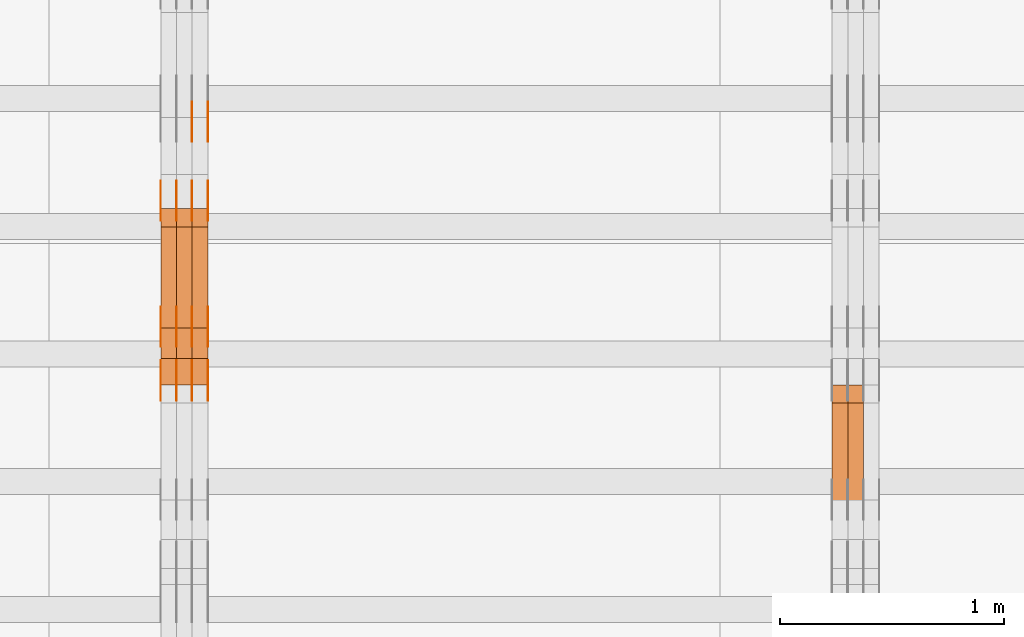
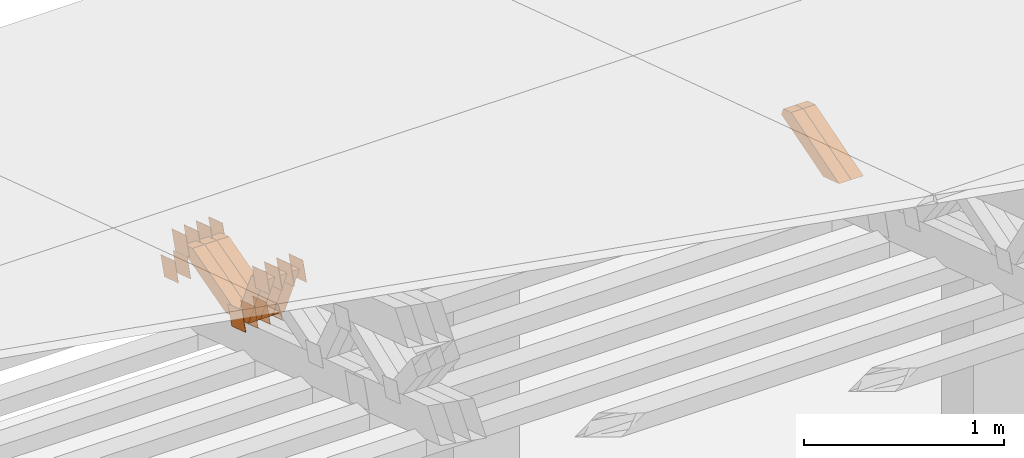
# One storey, part 217 of 385: 28 proxies.
"""IFC2X3 building model written with IfcOpenShell, lengths in millimetres."""

from ifc_helpers import new_model, entity, si_unit, converted_unit, derived_unit, direction, frame, origin, place, context, subcontext, project, spatial, polyline, outline, extrude, source, transform, mapped, material, type_object, type_shapes, element, save


model = new_model("IFC2X3")

# Units and contexts
model_context = context("Model", 3, precision=0.01, world=origin(), true_north=direction((6.12303176911189e-17, 1.0)))
body_context = subcontext(model_context, "Body", "Model", "MODEL_VIEW")
ifc_project = project(units=[si_unit("LENGTHUNIT", "METRE", prefix="MILLI"), si_unit("AREAUNIT", "SQUARE_METRE"), si_unit("VOLUMEUNIT", "CUBIC_METRE"), converted_unit("PLANEANGLEUNIT", "DEGREE", entity("IfcRatioMeasure", 0.0174532925199433), si_unit("PLANEANGLEUNIT", "RADIAN"), dimensions=[0, 0, 0, 0, 0, 0, 0]), si_unit("MASSUNIT", "GRAM", prefix="KILO"), derived_unit("MASSDENSITYUNIT", [(si_unit("MASSUNIT", "GRAM", prefix="KILO"), 1), (si_unit("LENGTHUNIT", "METRE"), -3)]), si_unit("TIMEUNIT", "SECOND"), si_unit("FREQUENCYUNIT", "HERTZ"), si_unit("THERMODYNAMICTEMPERATUREUNIT", "DEGREE_CELSIUS"), derived_unit("THERMALTRANSMITTANCEUNIT", [(si_unit("MASSUNIT", "GRAM", prefix="KILO"), 1), (si_unit("THERMODYNAMICTEMPERATUREUNIT", "KELVIN"), -1), (si_unit("TIMEUNIT", "SECOND"), -3)]), derived_unit("VOLUMETRICFLOWRATEUNIT", [(si_unit("LENGTHUNIT", "METRE"), 3), (si_unit("TIMEUNIT", "SECOND"), -1)]), si_unit("ELECTRICCURRENTUNIT", "AMPERE"), si_unit("ELECTRICVOLTAGEUNIT", "VOLT"), si_unit("POWERUNIT", "WATT"), si_unit("FORCEUNIT", "NEWTON", prefix="KILO"), si_unit("ILLUMINANCEUNIT", "LUX"), si_unit("LUMINOUSFLUXUNIT", "LUMEN"), si_unit("LUMINOUSINTENSITYUNIT", "CANDELA"), derived_unit("USERDEFINED", [(si_unit("MASSUNIT", "GRAM", prefix="KILO"), -1), (si_unit("LENGTHUNIT", "METRE"), -2), (si_unit("TIMEUNIT", "SECOND"), 3), (si_unit("LUMINOUSFLUXUNIT", "LUMEN"), 1)]), derived_unit("LINEARVELOCITYUNIT", [(si_unit("LENGTHUNIT", "METRE"), 1), (si_unit("TIMEUNIT", "SECOND"), -1)]), si_unit("PRESSUREUNIT", "PASCAL"), derived_unit("USERDEFINED", [(si_unit("LENGTHUNIT", "METRE"), -2), (si_unit("MASSUNIT", "GRAM", prefix="KILO"), 1), (si_unit("TIMEUNIT", "SECOND"), -2)])], contexts=[model_context])

# Site, building, storey
site_placement = place(None, origin())
site = spatial("IfcSite", under=ifc_project, at=site_placement, CompositionType="ELEMENT")
building_placement = place(site_placement, origin())
building = spatial("IfcBuilding", under=site, at=building_placement, CompositionType="ELEMENT")
storey_placement = place(building_placement, origin())
storey = spatial("IfcBuildingStorey", under=building, at=storey_placement, Name="Default", CompositionType="ELEMENT", Elevation=0.0)

# Proxies
ifc_material_1 = material(Name="IfcSurfaceStyle #252828")
building_element_proxy_type_1 = type_object("IfcBuildingElementProxyType", Name="T1-W23 252826", PredefinedType="NOTDEFINED", material=ifc_material_1)
shared_shape_1 = source(origin(), body_context, "Body", "SweptSolid", [
    extrude(outline(polyline([(-356.808656505462, -47.5000180192671), (144.726334557508, -47.5000180192671), (213.258834104997, -2.90494310381195e-05), (218.567145253444, 47.5000325439826), (-219.743657410487, 47.5000325439827), (-356.808656505462, -47.5000180192671)])), frame((218.567145253444, 47.5000325439826, 0.0), z_axis=(0.0, 0.0, 1.0), x_axis=(-1.0, 0.0, 0.0)), (0.0, 0.0, 1.0), 70.0),
])
type_shapes(building_element_proxy_type_1, [shared_shape_1])
proxy_1_placement = place(building_placement, frame((21315.0, 23128.2626953125, 1452.63940429688), z_axis=(-1.0, 0.0, 0.0), x_axis=(0.0, -0.957692700226705, -0.287792793399143)))
element("IfcBuildingElementProxy", 1, at=proxy_1_placement, inside=storey, type_object=building_element_proxy_type_1, material=ifc_material_1, Name="T1-W23", context=body_context, shape_type="MappedRepresentation", body=[
    mapped(shared_shape_1, transform((0.0, 0.0, 0.0), scale=1.0)),
])
ifc_material_2 = material(Name="IfcSurfaceStyle #252762")
building_element_proxy_type_2 = type_object("IfcBuildingElementProxyType", Name="T1-W23 252760", PredefinedType="NOTDEFINED", material=ifc_material_2)
shared_shape_2 = source(origin(), body_context, "Body", "SweptSolid", [
    extrude(outline(polyline([(-356.808656505462, -47.5000180192671), (144.726334557508, -47.5000180192671), (213.258834104997, -2.90494310381195e-05), (218.567145253444, 47.5000325439826), (-219.743657410487, 47.5000325439827), (-356.808656505462, -47.5000180192671)])), frame((218.567145253444, 47.5000325439826, 0.0), z_axis=(0.0, 0.0, 1.0), x_axis=(-1.0, 0.0, 0.0)), (0.0, 0.0, 1.0), 70.0),
])
type_shapes(building_element_proxy_type_2, [shared_shape_2])
proxy_2_placement = place(building_placement, frame((21245.0, 23128.2626953125, 1452.63940429688), z_axis=(-1.0, 0.0, 0.0), x_axis=(0.0, -0.957692700226705, -0.287792793399143)))
element("IfcBuildingElementProxy", 2, at=proxy_2_placement, inside=storey, type_object=building_element_proxy_type_2, material=ifc_material_2, Name="T1-W23", context=body_context, shape_type="MappedRepresentation", body=[
    mapped(shared_shape_2, transform((0.0, 0.0, 0.0), scale=1.0)),
])
ifc_material_3 = material(Name="IfcSurfaceStyle #230918")
building_element_proxy_type_3 = type_object("IfcBuildingElementProxyType", PredefinedType="NOTDEFINED", material=ifc_material_3)
shared_shape_3 = source(origin(), body_context, "Body", "SweptSolid", [
    extrude(outline(polyline([(-74.9998888504569, -59.9999264677525), (74.999884859074, -59.9999264677525), (74.9998699895559, 59.9999264677525), (-74.999865998173, 59.9999264677525), (-74.9998888504569, -59.9999264677525)])), frame((74.9999170714918, 60.0000016373507, 0.0), z_axis=(0.0, 0.0, 1.0), x_axis=(-1.0, 0.0, 0.0)), (0.0, 0.0, 1.0), 1.3),
])
type_shapes(building_element_proxy_type_3, [shared_shape_3])
proxy_3_placement = place(building_placement, frame((18386.3, 23182.5962361838, 1409.76695322432), z_axis=(-1.0, 0.0, 0.0), x_axis=(0.0, -0.951056516295154, 0.309016994374948)))
element("IfcBuildingElementProxy", 3, at=proxy_3_placement, inside=storey, type_object=building_element_proxy_type_3, material=ifc_material_3, context=body_context, shape_type="MappedRepresentation", body=[
    mapped(shared_shape_3, transform((0.0, 0.0, 0.0), scale=1.0)),
])
ifc_material_4 = material(Name="IfcSurfaceStyle #230861")
building_element_proxy_type_4 = type_object("IfcBuildingElementProxyType", PredefinedType="NOTDEFINED", material=ifc_material_4)
shared_shape_4 = source(origin(), body_context, "Body", "SweptSolid", [
    extrude(outline(polyline([(-74.9998888504569, -59.9999264677525), (74.999884859074, -59.9999264677525), (74.9998699895559, 59.9999264677525), (-74.999865998173, 59.9999264677525), (-74.9998888504569, -59.9999264677525)])), frame((74.9999170714918, 60.0000016373507, 0.0), z_axis=(0.0, 0.0, 1.0), x_axis=(-1.0, 0.0, 0.0)), (0.0, 0.0, 1.0), 1.3),
])
type_shapes(building_element_proxy_type_4, [shared_shape_4])
proxy_4_placement = place(building_placement, frame((18315.0, 23182.5962361838, 1409.76695322432), z_axis=(-1.0, 0.0, 0.0), x_axis=(0.0, -0.951056516295154, 0.309016994374948)))
element("IfcBuildingElementProxy", 4, at=proxy_4_placement, inside=storey, type_object=building_element_proxy_type_4, material=ifc_material_4, context=body_context, shape_type="MappedRepresentation", body=[
    mapped(shared_shape_4, transform((0.0, 0.0, 0.0), scale=1.0)),
])
ifc_material_5 = material(Name="IfcSurfaceStyle #230804")
building_element_proxy_type_5 = type_object("IfcBuildingElementProxyType", PredefinedType="NOTDEFINED", material=ifc_material_5)
shared_shape_5 = source(origin(), body_context, "Body", "SweptSolid", [
    extrude(outline(polyline([(-74.9998888504569, -59.9999264677525), (74.999884859074, -59.9999264677525), (74.9998699895559, 59.9999264677525), (-74.999865998173, 59.9999264677525), (-74.9998888504569, -59.9999264677525)])), frame((74.9999170714918, 60.0000016373507, 0.0), z_axis=(0.0, 0.0, 1.0), x_axis=(-1.0, 0.0, 0.0)), (0.0, 0.0, 1.0), 1.3),
])
type_shapes(building_element_proxy_type_5, [shared_shape_5])
proxy_5_placement = place(building_placement, frame((18316.3, 23182.5962361838, 1409.76695322432), z_axis=(-1.0, 0.0, 0.0), x_axis=(0.0, -0.951056516295154, 0.309016994374948)))
element("IfcBuildingElementProxy", 5, at=proxy_5_placement, inside=storey, type_object=building_element_proxy_type_5, material=ifc_material_5, context=body_context, shape_type="MappedRepresentation", body=[
    mapped(shared_shape_5, transform((0.0, 0.0, 0.0), scale=1.0)),
])
ifc_material_6 = material(Name="IfcSurfaceStyle #230747")
building_element_proxy_type_6 = type_object("IfcBuildingElementProxyType", PredefinedType="NOTDEFINED", material=ifc_material_6)
shared_shape_6 = source(origin(), body_context, "Body", "SweptSolid", [
    extrude(outline(polyline([(-74.9998888504569, -59.9999264677525), (74.999884859074, -59.9999264677525), (74.9998699895559, 59.9999264677525), (-74.999865998173, 59.9999264677525), (-74.9998888504569, -59.9999264677525)])), frame((74.9999170714918, 60.0000016373507, 0.0), z_axis=(0.0, 0.0, 1.0), x_axis=(-1.0, 0.0, 0.0)), (0.0, 0.0, 1.0), 1.29999999999999),
])
type_shapes(building_element_proxy_type_6, [shared_shape_6])
proxy_6_placement = place(building_placement, frame((18245.0, 23182.5962361838, 1409.76695322432), z_axis=(-1.0, 0.0, 0.0), x_axis=(0.0, -0.951056516295154, 0.309016994374948)))
element("IfcBuildingElementProxy", 6, at=proxy_6_placement, inside=storey, type_object=building_element_proxy_type_6, material=ifc_material_6, context=body_context, shape_type="MappedRepresentation", body=[
    mapped(shared_shape_6, transform((0.0, 0.0, 0.0), scale=1.0)),
])
ifc_material_7 = material(Name="IfcSurfaceStyle #230690")
building_element_proxy_type_7 = type_object("IfcBuildingElementProxyType", PredefinedType="NOTDEFINED", material=ifc_material_7)
shared_shape_7 = source(origin(), body_context, "Body", "SweptSolid", [
    extrude(outline(polyline([(-74.9998888504569, -59.9999264677525), (74.999884859074, -59.9999264677525), (74.9998699895559, 59.9999264677525), (-74.999865998173, 59.9999264677525), (-74.9998888504569, -59.9999264677525)])), frame((74.9999170714918, 60.0000016373507, 0.0), z_axis=(0.0, 0.0, 1.0), x_axis=(-1.0, 0.0, 0.0)), (0.0, 0.0, 1.0), 1.29999999999999),
])
type_shapes(building_element_proxy_type_7, [shared_shape_7])
proxy_7_placement = place(building_placement, frame((18246.3, 23182.5962361838, 1409.76695322432), z_axis=(-1.0, 0.0, 0.0), x_axis=(0.0, -0.951056516295154, 0.309016994374948)))
element("IfcBuildingElementProxy", 7, at=proxy_7_placement, inside=storey, type_object=building_element_proxy_type_7, material=ifc_material_7, context=body_context, shape_type="MappedRepresentation", body=[
    mapped(shared_shape_7, transform((0.0, 0.0, 0.0), scale=1.0)),
])
ifc_material_8 = material(Name="IfcSurfaceStyle #230633")
building_element_proxy_type_8 = type_object("IfcBuildingElementProxyType", PredefinedType="NOTDEFINED", material=ifc_material_8)
shared_shape_8 = source(origin(), body_context, "Body", "SweptSolid", [
    extrude(outline(polyline([(-74.9998888504569, -59.9999264677525), (74.999884859074, -59.9999264677525), (74.9998699895559, 59.9999264677525), (-74.999865998173, 59.9999264677525), (-74.9998888504569, -59.9999264677525)])), frame((74.9999170714918, 60.0000016373507, 0.0), z_axis=(0.0, 0.0, 1.0), x_axis=(-1.0, 0.0, 0.0)), (0.0, 0.0, 1.0), 1.29999999999999),
])
type_shapes(building_element_proxy_type_8, [shared_shape_8])
proxy_8_placement = place(building_placement, frame((18175.0, 23182.5962361838, 1409.76695322432), z_axis=(-1.0, 0.0, 0.0), x_axis=(0.0, -0.951056516295154, 0.309016994374948)))
element("IfcBuildingElementProxy", 8, at=proxy_8_placement, inside=storey, type_object=building_element_proxy_type_8, material=ifc_material_8, context=body_context, shape_type="MappedRepresentation", body=[
    mapped(shared_shape_8, transform((0.0, 0.0, 0.0), scale=1.0)),
])
ifc_material_9 = material(Name="IfcSurfaceStyle #230576")
building_element_proxy_type_9 = type_object("IfcBuildingElementProxyType", PredefinedType="NOTDEFINED", material=ifc_material_9)
shared_shape_9 = source(origin(), body_context, "Body", "SweptSolid", [
    extrude(outline(polyline([(-75.000111611545, -60.0000599592451), (75.0000887592491, -60.0000599592451), (75.000111611545, 60.0000599592451), (-75.0000887592492, 60.0000599592451), (-75.000111611545, -60.0000599592451)])), frame((75.000111611545, 60.0000599592451, 0.0), z_axis=(0.0, 0.0, 1.0), x_axis=(-1.0, 0.0, 0.0)), (0.0, 0.0, 1.0), 1.3),
])
type_shapes(building_element_proxy_type_9, [shared_shape_9])
proxy_9_placement = place(building_placement, frame((18386.3, 23422.738257852, 1031.33757447264), z_axis=(-1.0, 0.0, 0.0), x_axis=(0.0, -0.951056516295124, 0.309016994375039)))
element("IfcBuildingElementProxy", 9, at=proxy_9_placement, inside=storey, type_object=building_element_proxy_type_9, material=ifc_material_9, context=body_context, shape_type="MappedRepresentation", body=[
    mapped(shared_shape_9, transform((0.0, 0.0, 0.0), scale=1.0)),
])
ifc_material_10 = material(Name="IfcSurfaceStyle #230519")
building_element_proxy_type_10 = type_object("IfcBuildingElementProxyType", PredefinedType="NOTDEFINED", material=ifc_material_10)
shared_shape_10 = source(origin(), body_context, "Body", "SweptSolid", [
    extrude(outline(polyline([(-75.000111611545, -60.0000599592451), (75.0000887592491, -60.0000599592451), (75.000111611545, 60.0000599592451), (-75.0000887592492, 60.0000599592451), (-75.000111611545, -60.0000599592451)])), frame((75.000111611545, 60.0000599592451, 0.0), z_axis=(0.0, 0.0, 1.0), x_axis=(-1.0, 0.0, 0.0)), (0.0, 0.0, 1.0), 1.3),
])
type_shapes(building_element_proxy_type_10, [shared_shape_10])
proxy_10_placement = place(building_placement, frame((18315.0, 23422.738257852, 1031.33757447264), z_axis=(-1.0, 0.0, 0.0), x_axis=(0.0, -0.951056516295124, 0.309016994375039)))
element("IfcBuildingElementProxy", 10, at=proxy_10_placement, inside=storey, type_object=building_element_proxy_type_10, material=ifc_material_10, context=body_context, shape_type="MappedRepresentation", body=[
    mapped(shared_shape_10, transform((0.0, 0.0, 0.0), scale=1.0)),
])
ifc_material_11 = material(Name="IfcSurfaceStyle #230462")
building_element_proxy_type_11 = type_object("IfcBuildingElementProxyType", PredefinedType="NOTDEFINED", material=ifc_material_11)
shared_shape_11 = source(origin(), body_context, "Body", "SweptSolid", [
    extrude(outline(polyline([(-75.000111611545, -60.0000599592451), (75.0000887592491, -60.0000599592451), (75.000111611545, 60.0000599592451), (-75.0000887592492, 60.0000599592451), (-75.000111611545, -60.0000599592451)])), frame((75.000111611545, 60.0000599592451, 0.0), z_axis=(0.0, 0.0, 1.0), x_axis=(-1.0, 0.0, 0.0)), (0.0, 0.0, 1.0), 1.3),
])
type_shapes(building_element_proxy_type_11, [shared_shape_11])
proxy_11_placement = place(building_placement, frame((18316.3, 23422.738257852, 1031.33757447264), z_axis=(-1.0, 0.0, 0.0), x_axis=(0.0, -0.951056516295124, 0.309016994375039)))
element("IfcBuildingElementProxy", 11, at=proxy_11_placement, inside=storey, type_object=building_element_proxy_type_11, material=ifc_material_11, context=body_context, shape_type="MappedRepresentation", body=[
    mapped(shared_shape_11, transform((0.0, 0.0, 0.0), scale=1.0)),
])
ifc_material_12 = material(Name="IfcSurfaceStyle #230405")
building_element_proxy_type_12 = type_object("IfcBuildingElementProxyType", PredefinedType="NOTDEFINED", material=ifc_material_12)
shared_shape_12 = source(origin(), body_context, "Body", "SweptSolid", [
    extrude(outline(polyline([(-75.000111611545, -60.0000599592451), (75.0000887592491, -60.0000599592451), (75.000111611545, 60.0000599592451), (-75.0000887592492, 60.0000599592451), (-75.000111611545, -60.0000599592451)])), frame((75.000111611545, 60.0000599592451, 0.0), z_axis=(0.0, 0.0, 1.0), x_axis=(-1.0, 0.0, 0.0)), (0.0, 0.0, 1.0), 1.29999999999999),
])
type_shapes(building_element_proxy_type_12, [shared_shape_12])
proxy_12_placement = place(building_placement, frame((18245.0, 23422.738257852, 1031.33757447264), z_axis=(-1.0, 0.0, 0.0), x_axis=(0.0, -0.951056516295124, 0.309016994375039)))
element("IfcBuildingElementProxy", 12, at=proxy_12_placement, inside=storey, type_object=building_element_proxy_type_12, material=ifc_material_12, context=body_context, shape_type="MappedRepresentation", body=[
    mapped(shared_shape_12, transform((0.0, 0.0, 0.0), scale=1.0)),
])
ifc_material_13 = material(Name="IfcSurfaceStyle #230348")
building_element_proxy_type_13 = type_object("IfcBuildingElementProxyType", PredefinedType="NOTDEFINED", material=ifc_material_13)
shared_shape_13 = source(origin(), body_context, "Body", "SweptSolid", [
    extrude(outline(polyline([(-75.000111611545, -60.0000599592451), (75.0000887592491, -60.0000599592451), (75.000111611545, 60.0000599592451), (-75.0000887592492, 60.0000599592451), (-75.000111611545, -60.0000599592451)])), frame((75.000111611545, 60.0000599592451, 0.0), z_axis=(0.0, 0.0, 1.0), x_axis=(-1.0, 0.0, 0.0)), (0.0, 0.0, 1.0), 1.29999999999999),
])
type_shapes(building_element_proxy_type_13, [shared_shape_13])
proxy_13_placement = place(building_placement, frame((18246.3, 23422.738257852, 1031.33757447264), z_axis=(-1.0, 0.0, 0.0), x_axis=(0.0, -0.951056516295124, 0.309016994375039)))
element("IfcBuildingElementProxy", 13, at=proxy_13_placement, inside=storey, type_object=building_element_proxy_type_13, material=ifc_material_13, context=body_context, shape_type="MappedRepresentation", body=[
    mapped(shared_shape_13, transform((0.0, 0.0, 0.0), scale=1.0)),
])
ifc_material_14 = material(Name="IfcSurfaceStyle #230291")
building_element_proxy_type_14 = type_object("IfcBuildingElementProxyType", PredefinedType="NOTDEFINED", material=ifc_material_14)
shared_shape_14 = source(origin(), body_context, "Body", "SweptSolid", [
    extrude(outline(polyline([(-75.000111611545, -60.0000599592451), (75.0000887592491, -60.0000599592451), (75.000111611545, 60.0000599592451), (-75.0000887592492, 60.0000599592451), (-75.000111611545, -60.0000599592451)])), frame((75.000111611545, 60.0000599592451, 0.0), z_axis=(0.0, 0.0, 1.0), x_axis=(-1.0, 0.0, 0.0)), (0.0, 0.0, 1.0), 1.29999999999999),
])
type_shapes(building_element_proxy_type_14, [shared_shape_14])
proxy_14_placement = place(building_placement, frame((18175.0, 23422.738257852, 1031.33757447264), z_axis=(-1.0, 0.0, 0.0), x_axis=(0.0, -0.951056516295124, 0.309016994375039)))
element("IfcBuildingElementProxy", 14, at=proxy_14_placement, inside=storey, type_object=building_element_proxy_type_14, material=ifc_material_14, context=body_context, shape_type="MappedRepresentation", body=[
    mapped(shared_shape_14, transform((0.0, 0.0, 0.0), scale=1.0)),
])
ifc_material_15 = material(Name="IfcSurfaceStyle #229892")
building_element_proxy_type_15 = type_object("IfcBuildingElementProxyType", PredefinedType="NOTDEFINED", material=ifc_material_15)
shared_shape_15 = source(origin(), body_context, "Body", "SweptSolid", [
    extrude(outline(polyline([(-74.9999766548731, -60.0000019113547), (75.000223715922, -60.0000019113547), (74.9997444633404, 60.0000019113548), (-74.9999915243893, 60.0000019113547), (-74.9999766548731, -60.0000019113547)])), frame((75.0002237159219, 60.0000770809529, 0.0), z_axis=(0.0, 0.0, 1.0), x_axis=(-1.0, 0.0, 0.0)), (0.0, 0.0, 1.0), 1.3),
])
type_shapes(building_element_proxy_type_15, [shared_shape_15])
proxy_15_placement = place(building_placement, frame((18386.3, 23985.88473314, 1148.76266928562), z_axis=(-1.0, 0.0, 0.0), x_axis=(0.0, -0.951056516295154, 0.309016994374948)))
element("IfcBuildingElementProxy", 15, at=proxy_15_placement, inside=storey, type_object=building_element_proxy_type_15, material=ifc_material_15, context=body_context, shape_type="MappedRepresentation", body=[
    mapped(shared_shape_15, transform((0.0, 0.0, 0.0), scale=1.0)),
])
ifc_material_16 = material(Name="IfcSurfaceStyle #229835")
building_element_proxy_type_16 = type_object("IfcBuildingElementProxyType", PredefinedType="NOTDEFINED", material=ifc_material_16)
shared_shape_16 = source(origin(), body_context, "Body", "SweptSolid", [
    extrude(outline(polyline([(-74.9999766548731, -60.0000019113547), (75.000223715922, -60.0000019113547), (74.9997444633404, 60.0000019113548), (-74.9999915243893, 60.0000019113547), (-74.9999766548731, -60.0000019113547)])), frame((75.0002237159219, 60.0000770809529, 0.0), z_axis=(0.0, 0.0, 1.0), x_axis=(-1.0, 0.0, 0.0)), (0.0, 0.0, 1.0), 1.3),
])
type_shapes(building_element_proxy_type_16, [shared_shape_16])
proxy_16_placement = place(building_placement, frame((18315.0, 23985.88473314, 1148.76266928562), z_axis=(-1.0, 0.0, 0.0), x_axis=(0.0, -0.951056516295154, 0.309016994374948)))
element("IfcBuildingElementProxy", 16, at=proxy_16_placement, inside=storey, type_object=building_element_proxy_type_16, material=ifc_material_16, context=body_context, shape_type="MappedRepresentation", body=[
    mapped(shared_shape_16, transform((0.0, 0.0, 0.0), scale=1.0)),
])
ifc_material_17 = material(Name="IfcSurfaceStyle #229778")
building_element_proxy_type_17 = type_object("IfcBuildingElementProxyType", PredefinedType="NOTDEFINED", material=ifc_material_17)
shared_shape_17 = source(origin(), body_context, "Body", "SweptSolid", [
    extrude(outline(polyline([(-74.9999766548731, -60.0000019113547), (75.000223715922, -60.0000019113547), (74.9997444633404, 60.0000019113548), (-74.9999915243893, 60.0000019113547), (-74.9999766548731, -60.0000019113547)])), frame((75.0002237159219, 60.0000770809529, 0.0), z_axis=(0.0, 0.0, 1.0), x_axis=(-1.0, 0.0, 0.0)), (0.0, 0.0, 1.0), 1.3),
])
type_shapes(building_element_proxy_type_17, [shared_shape_17])
proxy_17_placement = place(building_placement, frame((18316.3, 23985.88473314, 1148.76266928562), z_axis=(-1.0, 0.0, 0.0), x_axis=(0.0, -0.951056516295154, 0.309016994374948)))
element("IfcBuildingElementProxy", 17, at=proxy_17_placement, inside=storey, type_object=building_element_proxy_type_17, material=ifc_material_17, context=body_context, shape_type="MappedRepresentation", body=[
    mapped(shared_shape_17, transform((0.0, 0.0, 0.0), scale=1.0)),
])
ifc_material_18 = material(Name="IfcSurfaceStyle #229721")
building_element_proxy_type_18 = type_object("IfcBuildingElementProxyType", PredefinedType="NOTDEFINED", material=ifc_material_18)
shared_shape_18 = source(origin(), body_context, "Body", "SweptSolid", [
    extrude(outline(polyline([(-74.9999766548731, -60.0000019113547), (75.000223715922, -60.0000019113547), (74.9997444633404, 60.0000019113548), (-74.9999915243893, 60.0000019113547), (-74.9999766548731, -60.0000019113547)])), frame((75.0002237159219, 60.0000770809529, 0.0), z_axis=(0.0, 0.0, 1.0), x_axis=(-1.0, 0.0, 0.0)), (0.0, 0.0, 1.0), 1.29999999999999),
])
type_shapes(building_element_proxy_type_18, [shared_shape_18])
proxy_18_placement = place(building_placement, frame((18245.0, 23985.88473314, 1148.76266928562), z_axis=(-1.0, 0.0, 0.0), x_axis=(0.0, -0.951056516295154, 0.309016994374948)))
element("IfcBuildingElementProxy", 18, at=proxy_18_placement, inside=storey, type_object=building_element_proxy_type_18, material=ifc_material_18, context=body_context, shape_type="MappedRepresentation", body=[
    mapped(shared_shape_18, transform((0.0, 0.0, 0.0), scale=1.0)),
])
ifc_material_19 = material(Name="IfcSurfaceStyle #229664")
building_element_proxy_type_19 = type_object("IfcBuildingElementProxyType", PredefinedType="NOTDEFINED", material=ifc_material_19)
shared_shape_19 = source(origin(), body_context, "Body", "SweptSolid", [
    extrude(outline(polyline([(-74.9999766548731, -60.0000019113547), (75.000223715922, -60.0000019113547), (74.9997444633404, 60.0000019113548), (-74.9999915243893, 60.0000019113547), (-74.9999766548731, -60.0000019113547)])), frame((75.0002237159219, 60.0000770809529, 0.0), z_axis=(0.0, 0.0, 1.0), x_axis=(-1.0, 0.0, 0.0)), (0.0, 0.0, 1.0), 1.29999999999999),
])
type_shapes(building_element_proxy_type_19, [shared_shape_19])
proxy_19_placement = place(building_placement, frame((18246.3, 23985.88473314, 1148.76266928562), z_axis=(-1.0, 0.0, 0.0), x_axis=(0.0, -0.951056516295154, 0.309016994374948)))
element("IfcBuildingElementProxy", 19, at=proxy_19_placement, inside=storey, type_object=building_element_proxy_type_19, material=ifc_material_19, context=body_context, shape_type="MappedRepresentation", body=[
    mapped(shared_shape_19, transform((0.0, 0.0, 0.0), scale=1.0)),
])
ifc_material_20 = material(Name="IfcSurfaceStyle #229607")
building_element_proxy_type_20 = type_object("IfcBuildingElementProxyType", PredefinedType="NOTDEFINED", material=ifc_material_20)
shared_shape_20 = source(origin(), body_context, "Body", "SweptSolid", [
    extrude(outline(polyline([(-74.9999766548731, -60.0000019113547), (75.000223715922, -60.0000019113547), (74.9997444633404, 60.0000019113548), (-74.9999915243893, 60.0000019113547), (-74.9999766548731, -60.0000019113547)])), frame((75.0002237159219, 60.0000770809529, 0.0), z_axis=(0.0, 0.0, 1.0), x_axis=(-1.0, 0.0, 0.0)), (0.0, 0.0, 1.0), 1.29999999999999),
])
type_shapes(building_element_proxy_type_20, [shared_shape_20])
proxy_20_placement = place(building_placement, frame((18175.0, 23985.88473314, 1148.76266928562), z_axis=(-1.0, 0.0, 0.0), x_axis=(0.0, -0.951056516295154, 0.309016994374948)))
element("IfcBuildingElementProxy", 20, at=proxy_20_placement, inside=storey, type_object=building_element_proxy_type_20, material=ifc_material_20, context=body_context, shape_type="MappedRepresentation", body=[
    mapped(shared_shape_20, transform((0.0, 0.0, 0.0), scale=1.0)),
])
ifc_material_21 = material(Name="IfcSurfaceStyle #229550")
building_element_proxy_type_21 = type_object("IfcBuildingElementProxyType", PredefinedType="NOTDEFINED", material=ifc_material_21)
shared_shape_21 = source(origin(), body_context, "Body", "SweptSolid", [
    extrude(outline(polyline([(-74.9998841352385, -59.9999554917014), (74.9998707133932, -59.9999554917014), (74.999874704788, 59.9999554917014), (-74.9998612829427, 59.9999554917014), (-74.9998841352385, -59.9999554917014)])), frame((75.0000802775471, 60.0000306612849, 0.0), z_axis=(0.0, 0.0, 1.0), x_axis=(-1.0, 0.0, 0.0)), (0.0, 0.0, 1.0), 1.3),
])
type_shapes(building_element_proxy_type_21, [shared_shape_21])
proxy_21_placement = place(building_placement, frame((18386.3, 24338.8869142613, 728.405515087805), z_axis=(-1.0, 0.0, 0.0), x_axis=(0.0, -0.951056516295124, 0.309016994375039)))
element("IfcBuildingElementProxy", 21, at=proxy_21_placement, inside=storey, type_object=building_element_proxy_type_21, material=ifc_material_21, context=body_context, shape_type="MappedRepresentation", body=[
    mapped(shared_shape_21, transform((0.0, 0.0, 0.0), scale=1.0)),
])
ifc_material_22 = material(Name="IfcSurfaceStyle #229493")
building_element_proxy_type_22 = type_object("IfcBuildingElementProxyType", PredefinedType="NOTDEFINED", material=ifc_material_22)
shared_shape_22 = source(origin(), body_context, "Body", "SweptSolid", [
    extrude(outline(polyline([(-74.9998841352385, -59.9999554917014), (74.9998707133932, -59.9999554917014), (74.999874704788, 59.9999554917014), (-74.9998612829427, 59.9999554917014), (-74.9998841352385, -59.9999554917014)])), frame((75.0000802775471, 60.0000306612849, 0.0), z_axis=(0.0, 0.0, 1.0), x_axis=(-1.0, 0.0, 0.0)), (0.0, 0.0, 1.0), 1.3),
])
type_shapes(building_element_proxy_type_22, [shared_shape_22])
proxy_22_placement = place(building_placement, frame((18315.0, 24338.8869142613, 728.405515087805), z_axis=(-1.0, 0.0, 0.0), x_axis=(0.0, -0.951056516295124, 0.309016994375039)))
element("IfcBuildingElementProxy", 22, at=proxy_22_placement, inside=storey, type_object=building_element_proxy_type_22, material=ifc_material_22, context=body_context, shape_type="MappedRepresentation", body=[
    mapped(shared_shape_22, transform((0.0, 0.0, 0.0), scale=1.0)),
])
ifc_material_23 = material(Name="IfcSurfaceStyle #218066")
building_element_proxy_type_23 = type_object("IfcBuildingElementProxyType", Name="T1-W48 218064", PredefinedType="NOTDEFINED", material=ifc_material_23)
shared_shape_23 = source(origin(), body_context, "Body", "SweptSolid", [
    extrude(outline(polyline([(-179.014659681673, -47.5001725722734), (164.970934255612, -47.5001725722734), (158.689466064455, -0.000154807462590734), (117.249257288395, 47.5002499760047), (-261.894997926789, 47.5002499760047), (-179.014659681673, -47.5001725722734)])), frame((164.970934255612, 47.5002499760047, 0.0), z_axis=(0.0, 0.0, 1.0), x_axis=(-1.0, 0.0, 0.0)), (0.0, 0.0, 1.0), 70.0),
])
type_shapes(building_element_proxy_type_23, [shared_shape_23])
proxy_23_placement = place(building_placement, frame((18385.0, 23276.999081075, 1103.96808602322), z_axis=(-1.0, 0.0, 0.0), x_axis=(0.0, -0.392372359952232, 0.919806463961586)))
element("IfcBuildingElementProxy", 23, at=proxy_23_placement, inside=storey, type_object=building_element_proxy_type_23, material=ifc_material_23, Name="T1-W48", context=body_context, shape_type="MappedRepresentation", body=[
    mapped(shared_shape_23, transform((0.0, 0.0, 0.0), scale=1.0)),
])
ifc_material_24 = material(Name="IfcSurfaceStyle #218000")
building_element_proxy_type_24 = type_object("IfcBuildingElementProxyType", Name="T1-W48 217998", PredefinedType="NOTDEFINED", material=ifc_material_24)
shared_shape_24 = source(origin(), body_context, "Body", "SweptSolid", [
    extrude(outline(polyline([(-179.014659681673, -47.5001725722734), (164.970934255612, -47.5001725722734), (158.689466064455, -0.000154807462590734), (117.249257288395, 47.5002499760047), (-261.894997926789, 47.5002499760047), (-179.014659681673, -47.5001725722734)])), frame((164.970934255612, 47.5002499760047, 0.0), z_axis=(0.0, 0.0, 1.0), x_axis=(-1.0, 0.0, 0.0)), (0.0, 0.0, 1.0), 70.0),
])
type_shapes(building_element_proxy_type_24, [shared_shape_24])
proxy_24_placement = place(building_placement, frame((18315.0, 23276.999081075, 1103.96808602322), z_axis=(-1.0, 0.0, 0.0), x_axis=(0.0, -0.392372359952232, 0.919806463961586)))
element("IfcBuildingElementProxy", 24, at=proxy_24_placement, inside=storey, type_object=building_element_proxy_type_24, material=ifc_material_24, Name="T1-W48", context=body_context, shape_type="MappedRepresentation", body=[
    mapped(shared_shape_24, transform((0.0, 0.0, 0.0), scale=1.0)),
])
ifc_material_25 = material(Name="IfcSurfaceStyle #217934")
building_element_proxy_type_25 = type_object("IfcBuildingElementProxyType", Name="T1-W48 217932", PredefinedType="NOTDEFINED", material=ifc_material_25)
shared_shape_25 = source(origin(), body_context, "Body", "SweptSolid", [
    extrude(outline(polyline([(-179.014659681673, -47.5001725722734), (164.970934255612, -47.5001725722734), (158.689466064455, -0.000154807462590734), (117.249257288395, 47.5002499760047), (-261.894997926789, 47.5002499760047), (-179.014659681673, -47.5001725722734)])), frame((164.970934255612, 47.5002499760047, 0.0), z_axis=(0.0, 0.0, 1.0), x_axis=(-1.0, 0.0, 0.0)), (0.0, 0.0, 1.0), 70.0),
])
type_shapes(building_element_proxy_type_25, [shared_shape_25])
proxy_25_placement = place(building_placement, frame((18245.0, 23276.999081075, 1103.96808602322), z_axis=(-1.0, 0.0, 0.0), x_axis=(0.0, -0.392372359952232, 0.919806463961586)))
element("IfcBuildingElementProxy", 25, at=proxy_25_placement, inside=storey, type_object=building_element_proxy_type_25, material=ifc_material_25, Name="T1-W48", context=body_context, shape_type="MappedRepresentation", body=[
    mapped(shared_shape_25, transform((0.0, 0.0, 0.0), scale=1.0)),
])
ifc_material_26 = material(Name="IfcSurfaceStyle #217670")
building_element_proxy_type_26 = type_object("IfcBuildingElementProxyType", Name="T1-W16 217668", PredefinedType="NOTDEFINED", material=ifc_material_26)
shared_shape_26 = source(origin(), body_context, "Body", "SweptSolid", [
    extrude(outline(polyline([(-370.757125176074, -47.4999438400901), (145.934648032773, -47.4999438400902), (217.511780472151, -4.11857860007858e-05), (234.91308660316, 47.4999644329832), (-227.602389932009, 47.4999644329832), (-370.757125176074, -47.4999438400901)])), frame((234.913162148205, 47.5000075544853, 0.0), z_axis=(0.0, 0.0, 1.0), x_axis=(-1.0, 0.0, 0.0)), (0.0, 0.0, 1.0), 70.0),
])
type_shapes(building_element_proxy_type_26, [shared_shape_26])
proxy_26_placement = place(building_placement, frame((18385.0, 23927.1704945031, 1199.43003244777), z_axis=(-1.0, 0.0, 0.0), x_axis=(0.0, -0.963308155550006, -0.268397834288666)))
element("IfcBuildingElementProxy", 26, at=proxy_26_placement, inside=storey, type_object=building_element_proxy_type_26, material=ifc_material_26, Name="T1-W16", context=body_context, shape_type="MappedRepresentation", body=[
    mapped(shared_shape_26, transform((0.0, 0.0, 0.0), scale=1.0)),
])
ifc_material_27 = material(Name="IfcSurfaceStyle #217604")
building_element_proxy_type_27 = type_object("IfcBuildingElementProxyType", Name="T1-W16 217602", PredefinedType="NOTDEFINED", material=ifc_material_27)
shared_shape_27 = source(origin(), body_context, "Body", "SweptSolid", [
    extrude(outline(polyline([(-370.757125176074, -47.4999438400901), (145.934648032773, -47.4999438400902), (217.511780472151, -4.11857860007858e-05), (234.91308660316, 47.4999644329832), (-227.602389932009, 47.4999644329832), (-370.757125176074, -47.4999438400901)])), frame((234.913162148205, 47.5000075544853, 0.0), z_axis=(0.0, 0.0, 1.0), x_axis=(-1.0, 0.0, 0.0)), (0.0, 0.0, 1.0), 70.0),
])
type_shapes(building_element_proxy_type_27, [shared_shape_27])
proxy_27_placement = place(building_placement, frame((18315.0, 23927.1704945031, 1199.43003244777), z_axis=(-1.0, 0.0, 0.0), x_axis=(0.0, -0.963308155550006, -0.268397834288666)))
element("IfcBuildingElementProxy", 27, at=proxy_27_placement, inside=storey, type_object=building_element_proxy_type_27, material=ifc_material_27, Name="T1-W16", context=body_context, shape_type="MappedRepresentation", body=[
    mapped(shared_shape_27, transform((0.0, 0.0, 0.0), scale=1.0)),
])
ifc_material_28 = material(Name="IfcSurfaceStyle #217538")
building_element_proxy_type_28 = type_object("IfcBuildingElementProxyType", Name="T1-W16 217536", PredefinedType="NOTDEFINED", material=ifc_material_28)
shared_shape_28 = source(origin(), body_context, "Body", "SweptSolid", [
    extrude(outline(polyline([(-370.757125176074, -47.4999438400901), (145.934648032773, -47.4999438400902), (217.511780472151, -4.11857860007858e-05), (234.91308660316, 47.4999644329832), (-227.602389932009, 47.4999644329832), (-370.757125176074, -47.4999438400901)])), frame((234.913162148205, 47.5000075544853, 0.0), z_axis=(0.0, 0.0, 1.0), x_axis=(-1.0, 0.0, 0.0)), (0.0, 0.0, 1.0), 70.0),
])
type_shapes(building_element_proxy_type_28, [shared_shape_28])
proxy_28_placement = place(building_placement, frame((18245.0, 23927.1704945031, 1199.43003244777), z_axis=(-1.0, 0.0, 0.0), x_axis=(0.0, -0.963308155550006, -0.268397834288666)))
element("IfcBuildingElementProxy", 28, at=proxy_28_placement, inside=storey, type_object=building_element_proxy_type_28, material=ifc_material_28, Name="T1-W16", context=body_context, shape_type="MappedRepresentation", body=[
    mapped(shared_shape_28, transform((0.0, 0.0, 0.0), scale=1.0)),
])

save(model, "model.ifc")
